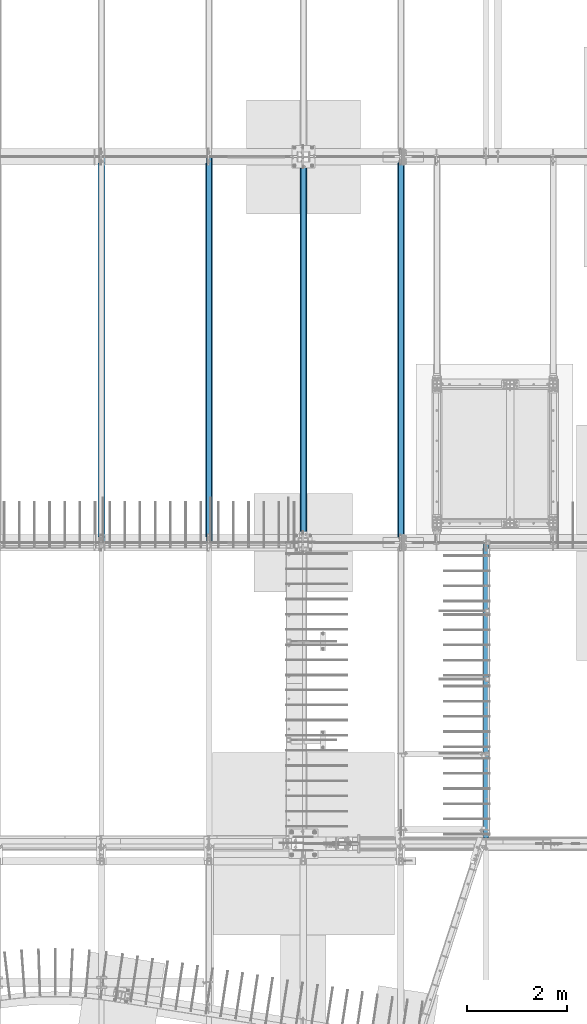
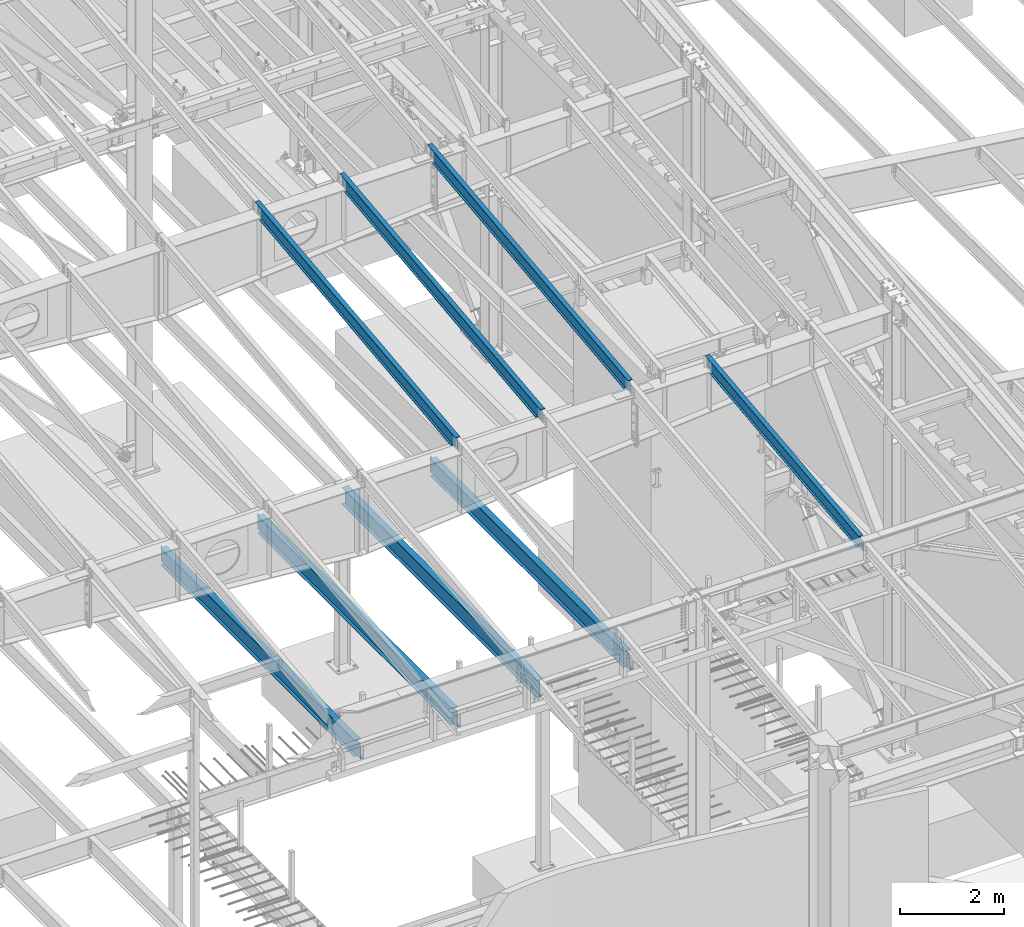
# One storey, part 719 of 1179: 8 beams, 8 elements without a shape of their own.
"""IFC2X3 building model written with IfcOpenShell, lengths in millimetres."""

from ifc_helpers import new_model, si_unit, frame, origin_with_axes, place, context, subcontext, project, spatial, faceted_brep, material, type_object, element, aggregate, save


model = new_model("IFC2X3")

# Units and contexts
model_context = context("Model", 3, precision=1e-05, world=origin_with_axes())
body_context = subcontext(model_context, "Body", "Model", "MODEL_VIEW")
ifc_project = project(units=[si_unit("LENGTHUNIT", "METRE", prefix="MILLI"), si_unit("AREAUNIT", "SQUARE_METRE"), si_unit("VOLUMEUNIT", "CUBIC_METRE"), si_unit("MASSUNIT", "GRAM", prefix="KILO"), si_unit("TIMEUNIT", "SECOND"), si_unit("PLANEANGLEUNIT", "RADIAN"), si_unit("SOLIDANGLEUNIT", "STERADIAN"), si_unit("THERMODYNAMICTEMPERATUREUNIT", "DEGREE_CELSIUS"), si_unit("LUMINOUSINTENSITYUNIT", "LUMEN")], contexts=[model_context])

# Site, building, storey
site_placement = place(None, origin_with_axes())
site = spatial("IfcSite", under=ifc_project, at=site_placement, CompositionType="ELEMENT")
building_placement = place(site_placement, origin_with_axes())
building = spatial("IfcBuilding", under=site, at=building_placement, Name="Undefined", CompositionType="ELEMENT")
storey_placement = place(building_placement, origin_with_axes())
storey = spatial("IfcBuildingStorey", under=building, at=storey_placement, Name="Undefined", CompositionType="ELEMENT", Elevation=0.0)

# Assembly, beam
assembly_1_placement = place(storey_placement, origin_with_axes())
assembly_1 = element("IfcElementAssembly", 1, at=assembly_1_placement, inside=storey, Name="BEAM", AssemblyPlace="NOTDEFINED", PredefinedType="RIGID_FRAME")
ifc_material = material(Name="STEEL/A992")
beam_type_1 = type_object("IfcBeamType", Name="W12X14", PredefinedType="NOTDEFINED")
beam_1_placement = place(assembly_1_placement, frame((20129.5, 5452.5431792468, 9711.23798851528), z_axis=(0.0, -0.112284087038017, 0.993676146336441), x_axis=(0.0, 0.993676146336441, 0.112284087038017)))
beam_1 = element("IfcBeam", 2, at=beam_1_placement, type_object=beam_type_1, material=ifc_material, Name="BEAM", ObjectType="W12X14", context=body_context, shape_type="Brep", body=[
    faceted_brep([(5871.37503272929, -2.38124999999854, -144.462500002917), (5871.37503272929, -50.7999999999993, -144.462500002917), (5870.65749114864, -50.7999999999993, -150.812500002912), (5870.65749114864, 50.7999999999993, -150.812500002912), (5871.37503272929, 50.7999999999993, -144.462500002917), (5871.37503272928, 2.38124783346939, -144.462500002968), (5874.19845246322, 2.38122628119891, -119.476191482236), (5874.19845246322, -2.38124999999854, -119.476191482236), (5875.70477851863, 2.38122688934163, -114.755394783042), (5875.70477851863, -2.38124999999854, -114.755394783042), (5878.90301301472, 2.38122737693629, -110.970393360541), (5878.90301301472, -2.38124999999854, -110.970393360541), (5883.30625374162, 2.38122766974266, -108.697419370077), (5883.30625374162, -2.38124999999854, -108.697419370077), (5888.24414721426, 2.38122772319184, -108.282512497075), (5888.24414721426, -2.38124999999854, -108.282512497075), (6045.98095926941, -2.38124999999854, -126.106563095373), (6045.98095929506, 2.38124999999854, -126.10656309827), (6076.55490468175, -50.7999999999993, 144.462499996846), (6077.27244626239, -50.7999999999993, 150.812499996842), (114.228614327105, -50.7999999999993, 150.812499999873), (113.511072746461, -50.7999999999993, 144.462499999876), (6077.27244626239, 50.7999999999993, 150.812499996842), (114.228614327105, 50.7999999999993, 150.812499999873), (6076.55490468175, 50.7999999999993, 144.462499996846), (113.511072746461, 50.7999999999993, 144.462499999876), (6076.55490468175, 2.38124999999854, 144.462499996846), (113.511072746461, 2.38124999999854, 144.462499999876), (136.689207968453, 50.7999999999993, -144.462500000005), (136.689207968449, 50.7999999999993, -150.8125), (136.689200027815, 2.38132415300061, -150.812500000002), (136.689200027785, 2.38117582134146, -144.462500001737), (-15.7107912112788, 2.38134914656257, -150.812499999922), (-14.9932496306401, 2.38124999999854, -144.462499999927), (136.689191329944, -50.7999999999993, -144.462500000003), (136.689199270568, -2.38124999999854, -144.462500000005), (136.689199270599, -2.38117588245223, -150.8125), (136.689191329941, -50.7999999999993, -150.8125), (-14.9932496306401, -2.38124999999854, -144.462499999927), (-15.7107912112788, -2.38115088886843, -150.812499999922), (-14.7278431263294, -2.38124999999854, -142.113742314172), (10.9745586429563, -2.38124999999854, 85.3438094690136), (10.9745586429563, 2.38124999999854, 85.3438094690136), (-14.7278305511045, 2.38124999999854, -142.113631027696), (93.0025247126168, -2.38124999999854, 76.0747580626012), (93.0025247126168, 2.38124999999854, 76.0747580626012), (97.9404181857699, -2.38124999999854, 76.4896649350048), (97.9404181857699, 2.38124999999854, 76.4896649350048), (102.343658913291, -2.38124999999854, 78.7626389252728), (102.343658913291, 2.38124999999854, 78.7626389252728), (105.541893409889, -2.38124999999854, 82.5476403479479), (105.541893409889, 2.38124999999854, 82.5476403479479), (107.048219465527, -2.38124999999854, 87.2684370475545), (107.048219465527, 2.38124999999854, 87.2684370475545), (113.511072746461, -2.38124999999854, 144.462499999876), (6076.55490468175, -2.38124999999854, 144.462499996846)], [[[0, 1, 2, 3, 4, 5, 6, 7]], [[7, 6, 8, 9]], [[9, 8, 10, 11]], [[11, 10, 12, 13]], [[13, 12, 14, 15]], [[16, 15, 14, 17]], [[18, 19, 20, 21]], [[19, 22, 23, 20]], [[22, 24, 25, 23]], [[24, 26, 27, 25]], [[28, 29, 30, 31]], [[31, 30, 32, 33]], [[34, 35, 36, 37]], [[38, 39, 36, 35]], [[40, 41, 42, 43, 33, 32, 39, 38]], [[44, 45, 42, 41]], [[46, 47, 45, 44]], [[48, 49, 47, 46]], [[50, 51, 49, 48]], [[52, 53, 51, 50]], [[20, 23, 25, 27, 53, 52, 54, 21]], [[55, 18, 21, 54]], [[26, 24, 22, 19, 18, 55, 16, 17]], [[12, 10, 8, 6, 5, 31, 33, 43, 42, 45, 47, 49, 51, 53, 27, 26, 17, 14]], [[28, 31, 5, 4]], [[29, 28, 4, 3]], [[37, 36, 39, 32, 30, 29, 3, 2]], [[34, 37, 2, 1]], [[35, 34, 1, 0]], [[55, 54, 52, 50, 48, 46, 44, 41, 40, 38, 35, 0, 7, 9, 11, 13, 15, 16]]]),
])
aggregate(assembly_1, [beam_1])

assembly_2_placement = place(storey_placement, origin_with_axes())
assembly_2 = element("IfcElementAssembly", 3, at=assembly_2_placement, inside=storey, Name="BEAM", AssemblyPlace="NOTDEFINED", PredefinedType="RIGID_FRAME")
beam_type_2 = type_object("IfcBeamType", Name="W16X31", PredefinedType="NOTDEFINED")
beam_2_placement = place(assembly_2_placement, frame((14566.9, 11480.8, 3900.4875), z_axis=(0.0, 0.0, 1.0), x_axis=(0.0, 1.0, 0.0)))
beam_2 = element("IfcBeam", 4, at=beam_2_placement, type_object=beam_type_2, material=ifc_material, Name="BEAM", ObjectType="W16X31", context=body_context, shape_type="Brep", body=[
    faceted_brep([(104.775000190735, -3.17499999999927, 169.8625), (104.775000190735, 3.17497090526012, 169.8625), (17.4625000000015, 3.17499999999927, 169.8625), (17.4625000000015, -3.17499999999927, 169.8625), (109.635079708782, -3.17499999999927, 170.829229922588), (109.635079708782, 3.17497028100843, 170.829229922588), (113.755256176935, -3.17499999999927, 173.582243823066), (113.755256176935, 3.17496850329189, 173.582243823066), (116.508270077413, -3.17499999999927, 177.702420291219), (116.508270077413, 3.17496584275432, 177.702420291219), (117.475, -3.17499999999927, 182.562499809265), (117.475, 3.17496270443371, 182.562499809265), (117.474999999999, -69.8499999999985, 201.6125), (117.474999999999, 69.8499999999985, 201.6125), (117.474999999999, 69.8499999999985, 190.5), (117.474999999999, 3.17499999999927, 190.5), (117.474999999999, -3.17499999999927, 190.5), (117.474999999999, -69.8499999999985, 190.5), (7601.74375, 3.17499999999927, -190.5), (7601.74375, 69.8499999999985, -190.5), (144.462499999994, 69.8499999999985, -190.5), (144.462499999994, 3.17549991607666, -190.5), (17.4624999999942, -3.17499999999927, -190.5), (17.4624999999942, -69.8499999999985, -190.5), (7728.74375, -69.8499999999985, -190.5), (7728.74375, -3.17499999999927, -190.5), (17.4624999999942, -69.8499999999985, -201.6125), (7728.74375, -69.8499999999985, -201.6125), (7601.74375, 69.8499999999985, -201.6125), (7601.74375, 3.17561705897606, -201.6125), (7728.74375, 3.17561705897606, -201.6125), (17.4624999999942, 3.17549991607666, -201.6125), (144.462499999994, 3.17549991607666, -201.6125), (144.462499999994, 69.8499999999985, -201.6125), (17.4624999999942, 3.17499999999927, -190.5), (7728.74375, 3.17499999999927, -190.5), (7728.74375, 3.17499999999927, 169.8625), (7728.74375, -3.17499999999927, 169.8625), (7633.49374980927, 3.17499999999927, 169.8625), (7633.49374980927, -3.17499999999927, 169.8625), (7628.63367029122, 3.17499999999927, 170.829229922588), (7628.63367029122, -3.17499999999927, 170.829229922588), (7624.51349382307, 3.17499999999927, 173.582243823066), (7624.51349382307, -3.17499999999927, 173.582243823066), (7621.76047992259, 3.17499999999927, 177.70242029122), (7621.76047992259, -3.17499999999927, 177.70242029122), (7620.79375, 3.17499999999927, 182.562499809265), (7620.79375, -3.17499999999927, 182.562499809265), (7620.79375, -69.8499999999985, 201.6125), (7620.79375, -69.8499999999985, 190.5), (7620.79375, -3.17499999999927, 190.5), (7620.79375, 3.17499999999927, 190.5), (7620.79375, 69.8499999999985, 190.5), (7620.79375, 69.8499999999985, 201.6125)], [[[0, 1, 2, 3]], [[4, 5, 1, 0]], [[6, 7, 5, 4]], [[8, 9, 7, 6]], [[10, 11, 9, 8]], [[12, 13, 14, 15, 11, 10, 16, 17]], [[18, 19, 20, 21]], [[22, 23, 24, 25]], [[23, 26, 27, 24]], [[28, 29, 30, 27, 26, 31, 32, 33]], [[21, 32, 31, 34]], [[20, 33, 32, 21]], [[19, 28, 33, 20]], [[18, 29, 28, 19]], [[35, 30, 29, 18]], [[25, 24, 27, 30, 35, 36, 37]], [[37, 36, 38, 39]], [[39, 38, 40, 41]], [[41, 40, 42, 43]], [[43, 42, 44, 45]], [[45, 44, 46, 47]], [[48, 49, 50, 47, 46, 51, 52, 53]], [[49, 48, 12, 17]], [[50, 49, 17, 16]], [[8, 6, 4, 0, 3, 22, 25, 37, 39, 41, 43, 45, 47, 50, 16, 10]], [[34, 31, 26, 23, 22, 3, 2]], [[51, 46, 44, 42, 40, 38, 36, 35, 18, 21, 34, 2, 1, 5, 7, 9, 11, 15]], [[52, 51, 15, 14]], [[53, 52, 14, 13]], [[48, 53, 13, 12]]]),
])
aggregate(assembly_2, [beam_2])

assembly_3_placement = place(storey_placement, origin_with_axes())
assembly_3 = element("IfcElementAssembly", 5, at=assembly_3_placement, inside=storey, Name="BEAM", AssemblyPlace="NOTDEFINED", PredefinedType="RIGID_FRAME")
beam_3_placement = place(assembly_3_placement, frame((12407.9, 11480.8, 3900.4875), z_axis=(0.0, 0.0, 1.0), x_axis=(0.0, 1.0, 0.0)))
beam_3 = element("IfcBeam", 6, at=beam_3_placement, type_object=beam_type_2, material=ifc_material, Name="BEAM", ObjectType="W16X31", context=body_context, shape_type="Brep", body=[
    faceted_brep([(7620.79375, -69.8499999999985, 201.6125), (7620.79375, -69.8499999999985, 190.5), (7620.79375, -3.17499999999927, 190.5), (7620.79375, -3.17499999999927, 182.562499809265), (7620.79375, 3.17499999999927, 182.562499809265), (7620.79375, 3.17499999999927, 190.5), (7620.79375, 69.8499999999985, 190.5), (7620.79375, 69.8499999999985, 201.6125), (7621.76047992259, -3.17499999999927, 177.70242029122), (7621.76047992259, 3.17499999999927, 177.70242029122), (7624.51349382307, -3.17499999999927, 173.582243823066), (7624.51349382307, 3.17499999999927, 173.582243823066), (7628.63367029122, -3.17499999999927, 170.829229922588), (7628.63367029122, 3.17499999999927, 170.829229922588), (7633.49374980927, -3.17499999999927, 169.8625), (7633.49374980927, 3.17499999999927, 169.8625), (7728.74375, -3.17499999999927, 169.8625), (7728.74375, 3.17499999999927, 169.8625), (117.474999999999, -69.8499999999985, 201.6125), (117.474999999999, 69.8499999999985, 201.6125), (117.474999999999, 69.8499999999985, 190.5), (117.474999999999, 3.17499999999927, 190.5), (117.475, 3.17496270443371, 182.562499809265), (117.475, -3.17499999999927, 182.562499809265), (117.474999999999, -3.17499999999927, 190.5), (117.474999999999, -69.8499999999985, 190.5), (116.508270077413, 3.17496584275432, 177.702420291219), (116.508270077413, -3.17499999999927, 177.702420291219), (113.755256176935, 3.17496850329189, 173.582243823066), (113.755256176935, -3.17499999999927, 173.582243823066), (109.635079708782, 3.17497028100843, 170.829229922588), (109.635079708782, -3.17499999999927, 170.829229922588), (104.775000190735, 3.17497090526012, 169.8625), (104.775000190735, -3.17499999999927, 169.8625), (17.4625000000015, 3.17499999999927, 169.8625), (17.4625000000015, -3.17499999999927, 169.8625), (17.4624999999942, 3.17499999999927, -190.5), (17.4624999999942, 3.17549991607666, -201.6125), (17.4624999999942, -69.8499999999985, -201.6125), (17.4624999999942, -69.8499999999985, -190.5), (17.4624999999942, -3.17499999999927, -190.5), (144.462499999994, 3.17549991607666, -190.5), (144.462499999994, 3.17549991607666, -201.6125), (144.462499999994, 69.8499999999985, -190.5), (144.462499999994, 69.8499999999985, -201.6125), (7601.74375, 3.17499999999927, -190.5), (7601.74375, 69.8499999999985, -190.5), (7601.74375, 69.8499999999985, -201.6125), (7601.74375, 3.17561705897606, -201.6125), (7728.74375, 3.17499999999927, -190.5), (7728.74375, 3.17561705897606, -201.6125), (7728.74375, -69.8499999999985, -201.6125), (7728.74375, -69.8499999999985, -190.5), (7728.74375, -3.17499999999927, -190.5)], [[[0, 1, 2, 3, 4, 5, 6, 7]], [[8, 9, 4, 3]], [[10, 11, 9, 8]], [[12, 13, 11, 10]], [[14, 15, 13, 12]], [[16, 17, 15, 14]], [[18, 19, 20, 21, 22, 23, 24, 25]], [[23, 22, 26, 27]], [[27, 26, 28, 29]], [[29, 28, 30, 31]], [[31, 30, 32, 33]], [[33, 32, 34, 35]], [[36, 37, 38, 39, 40, 35, 34]], [[41, 42, 37, 36]], [[43, 44, 42, 41]], [[45, 46, 43, 41]], [[46, 47, 44, 43]], [[45, 48, 47, 46]], [[49, 50, 48, 45]], [[47, 48, 50, 51, 38, 37, 42, 44]], [[39, 38, 51, 52]], [[40, 39, 52, 53]], [[27, 29, 31, 33, 35, 40, 53, 16, 14, 12, 10, 8, 3, 2, 24, 23]], [[2, 1, 25, 24]], [[1, 0, 18, 25]], [[0, 7, 19, 18]], [[7, 6, 20, 19]], [[6, 5, 21, 20]], [[5, 4, 9, 11, 13, 15, 17, 49, 45, 41, 36, 34, 32, 30, 28, 26, 22, 21]], [[53, 52, 51, 50, 49, 17, 16]]]),
])
aggregate(assembly_3, [beam_3])

assembly_4_placement = place(storey_placement, origin_with_axes())
assembly_4 = element("IfcElementAssembly", 7, at=assembly_4_placement, inside=storey, Name="BEAM", AssemblyPlace="NOTDEFINED", PredefinedType="RIGID_FRAME")
beam_4_placement = place(assembly_4_placement, frame((16459.2, 11480.8, 3900.4875), z_axis=(0.0, 0.0, 1.0), x_axis=(0.0, 1.0, 0.0)))
beam_4 = element("IfcBeam", 8, at=beam_4_placement, type_object=beam_type_2, material=ifc_material, Name="BEAM", ObjectType="W16X31", context=body_context, shape_type="Brep", body=[
    faceted_brep([(114.299999999999, -69.8500000000004, -190.5), (114.299999999999, -69.8500000000004, -201.6125), (7632.7, -69.8500000000004, -201.6125), (7632.7, -69.8500000000004, -190.5), (114.299999999999, -3.17499999999927, -190.5), (7632.7, -3.17499999999927, -190.5), (114.299999999999, -3.17499999999927, 190.5), (7632.7, -3.17499999999927, 190.5), (114.299999999999, -69.8500000000004, 190.5), (7632.7, -69.8500000000004, 190.5), (114.299999999999, -69.8500000000004, 201.6125), (7632.7, -69.8500000000004, 201.6125), (114.299999999999, 69.8500000000004, 201.6125), (7632.7, 69.8500000000004, 201.6125), (114.299999999999, 69.8500000000004, 190.5), (7632.7, 69.8500000000004, 190.5), (114.299999999999, 3.17499999999927, 190.5), (7632.7, 3.17499999999927, 190.5), (114.299999999999, 3.17499999999927, -190.5), (7632.7, 3.17499999999927, 164.252500725411), (7632.7, 3.17499999999927, -142.0275032968), (7632.7, 3.17499999999927, -190.5), (114.299999999999, 69.8500000000004, -190.5), (7632.7, 69.8500000000004, -190.5), (114.299999999999, 69.8500000000004, -201.6125), (7632.7, 69.8500000000004, -201.6125)], [[[0, 1, 2, 3]], [[4, 0, 3, 5]], [[6, 4, 5, 7]], [[8, 6, 7, 9]], [[10, 8, 9, 11]], [[12, 10, 11, 13]], [[14, 12, 13, 15]], [[16, 14, 15, 17]], [[18, 16, 17, 19, 20, 21]], [[22, 18, 21, 23]], [[1, 0, 4, 6, 8, 10, 12, 14, 16, 18, 22, 24]], [[1, 24, 25, 2]], [[21, 20, 19, 17, 15, 13, 11, 9, 7, 5, 3, 2, 25, 23]], [[24, 22, 23, 25]]]),
])
aggregate(assembly_4, [beam_4])

assembly_5_placement = place(storey_placement, origin_with_axes())
assembly_5 = element("IfcElementAssembly", 9, at=assembly_5_placement, inside=storey, Name="BEAM", AssemblyPlace="NOTDEFINED", PredefinedType="RIGID_FRAME")
beam_5_placement = place(assembly_5_placement, frame((18415.0, 11480.8, 3900.4875), z_axis=(0.0, 0.0, 1.0), x_axis=(0.0, 1.0, 0.0)))
beam_5 = element("IfcBeam", 10, at=beam_5_placement, type_object=beam_type_2, material=ifc_material, Name="BEAM", ObjectType="W16X31", context=body_context, shape_type="Brep", body=[
    faceted_brep([(104.775000190735, -3.17499999999927, 169.8625), (104.775000190735, 3.17497090526012, 169.8625), (17.4625000000015, 3.17499999999927, 169.8625), (17.4625000000015, -3.17499999999927, 169.8625), (109.635079708782, -3.17499999999927, 170.829229922588), (109.635079708782, 3.17497028100843, 170.829229922588), (113.755256176935, -3.17499999999927, 173.582243823066), (113.755256176935, 3.17496850329189, 173.582243823066), (116.508270077413, -3.17499999999927, 177.702420291219), (116.508270077413, 3.17496584275432, 177.702420291219), (117.475, -3.17499999999927, 182.562499809265), (117.475, 3.17496270443371, 182.562499809265), (117.474999999999, -69.8499999999985, 201.6125), (117.474999999999, 69.8499999999985, 201.6125), (117.474999999999, 69.8499999999985, 190.5), (117.474999999999, 3.17499999999927, 190.5), (117.474999999999, -3.17499999999927, 190.5), (117.474999999999, -69.8499999999985, 190.5), (7601.74375, 3.17499999999927, -190.5), (7601.74375, 69.8499999999985, -190.5), (144.462499999994, 69.8499999999985, -190.5), (144.462499999994, 3.17549991607666, -190.5), (17.4624999999942, -3.17499999999927, -190.5), (17.4624999999942, -69.8499999999985, -190.5), (7728.74375, -69.8499999999985, -190.5), (7728.74375, -3.17499999999927, -190.5), (17.4624999999942, -69.8499999999985, -201.6125), (7728.74375, -69.8499999999985, -201.6125), (7601.74375, 69.8499999999985, -201.6125), (7601.74375, 3.17561705897606, -201.6125), (7728.74375, 3.17561705897606, -201.6125), (17.4624999999942, 3.17549991607666, -201.6125), (144.462499999994, 3.17549991607666, -201.6125), (144.462499999994, 69.8499999999985, -201.6125), (17.4624999999942, 3.17499999999927, -190.5), (7728.74375, 3.17499999999927, -190.5), (7728.74375, 3.17499999999927, 169.8625), (7728.74375, -3.17499999999927, 169.8625), (7633.49374980927, 3.17499999999927, 169.8625), (7633.49374980927, -3.17499999999927, 169.8625), (7628.63367029122, 3.17499999999927, 170.829229922588), (7628.63367029122, -3.17499999999927, 170.829229922588), (7624.51349382307, 3.17499999999927, 173.582243823066), (7624.51349382307, -3.17499999999927, 173.582243823066), (7621.76047992259, 3.17499999999927, 177.70242029122), (7621.76047992259, -3.17499999999927, 177.70242029122), (7620.79375, 3.17499999999927, 182.562499809265), (7620.79375, -3.17499999999927, 182.562499809265), (7620.79375, -69.8499999999985, 201.6125), (7620.79375, -69.8499999999985, 190.5), (7620.79375, -3.17499999999927, 190.5), (7620.79375, 3.17499999999927, 190.5), (7620.79375, 69.8499999999985, 190.5), (7620.79375, 69.8499999999985, 201.6125)], [[[0, 1, 2, 3]], [[4, 5, 1, 0]], [[6, 7, 5, 4]], [[8, 9, 7, 6]], [[10, 11, 9, 8]], [[12, 13, 14, 15, 11, 10, 16, 17]], [[18, 19, 20, 21]], [[22, 23, 24, 25]], [[23, 26, 27, 24]], [[28, 29, 30, 27, 26, 31, 32, 33]], [[21, 32, 31, 34]], [[20, 33, 32, 21]], [[19, 28, 33, 20]], [[18, 29, 28, 19]], [[35, 30, 29, 18]], [[25, 24, 27, 30, 35, 36, 37]], [[37, 36, 38, 39]], [[39, 38, 40, 41]], [[41, 40, 42, 43]], [[43, 42, 44, 45]], [[45, 44, 46, 47]], [[48, 49, 50, 47, 46, 51, 52, 53]], [[49, 48, 12, 17]], [[50, 49, 17, 16]], [[8, 6, 4, 0, 3, 22, 25, 37, 39, 41, 43, 45, 47, 50, 16, 10]], [[34, 31, 26, 23, 22, 3, 2]], [[51, 46, 44, 42, 40, 38, 36, 35, 18, 21, 34, 2, 1, 5, 7, 9, 11, 15]], [[52, 51, 15, 14]], [[53, 52, 14, 13]], [[48, 53, 13, 12]]]),
])
aggregate(assembly_5, [beam_5])

assembly_6_placement = place(storey_placement, origin_with_axes())
assembly_6 = element("IfcElementAssembly", 11, at=assembly_6_placement, inside=storey, Name="BEAM", AssemblyPlace="NOTDEFINED", PredefinedType="RIGID_FRAME")
beam_type_3 = type_object("IfcBeamType", Name="W12X22", PredefinedType="NOTDEFINED")
beam_6_placement = place(assembly_6_placement, frame((18415.0, 11498.2779321842, 10389.6051906331), z_axis=(0.0, -0.112284087038017, 0.993676146336441), x_axis=(0.0, 0.993676146336441, 0.112284087038017)))
beam_6 = element("IfcBeam", 12, at=beam_6_placement, type_object=beam_type_3, material=ifc_material, Name="BEAM", ObjectType="W12X22", context=body_context, shape_type="Brep", body=[
    faceted_brep([(7577.0768884033, -3.17499999999927, -144.46250000299), (7577.0768884033, -50.7999999999993, -144.46250000299), (7575.82119063717, -50.7999999999993, -155.575000002984), (7575.82119063717, 50.7999999999993, -155.575000002984), (7577.0768884033, 50.7999999999993, -144.46250000299), (7577.0768884033, 3.17499999999927, -144.46250000299), (7581.95449107047, 3.17499999999927, -101.29736815286), (7581.95449107047, -3.17499999999927, -101.29736815286), (7583.46081712589, 3.17499999999927, -96.5765714536519), (7583.46081712589, -3.17499999999927, -96.5765714536519), (7586.659051622, 3.17499999999927, -92.7915700311405), (7586.659051622, -3.17499999999927, -92.7915700311405), (7591.06229234892, 3.17499999999927, -90.5185960406798), (7591.06229234892, -3.17499999999927, -90.5185960406798), (7596.00018582157, 3.17499999999927, -90.103689167694), (7596.00018582157, -3.17499999999927, -90.103689167694), (7760.04684140558, -3.17499999999927, -108.640743718448), (7760.04684144763, 3.17499999999927, -108.640743723199), (6.38101702707718, -50.7999999999993, 155.574999999912), (5.12531926095107, -50.7999999999993, 144.46249999992), (7788.64717240277, -50.7999999999993, 144.462499996762), (7789.9028701689, -50.7999999999993, 155.574999996754), (6.38101702707718, 50.7999999999993, 155.574999999912), (7789.9028701689, 50.7999999999993, 155.574999996754), (5.12531926095107, 50.7999999999993, 144.46249999992), (7788.64717240277, 50.7999999999993, 144.462499996762), (5.12531926095107, 3.17499999999927, 144.46249999992), (7788.64717240277, 3.17499999999927, 144.462499996762), (151.613288428754, -3.17499999999927, -142.735230056252), (151.613288428754, 3.17499999999927, -142.735230056252), (151.418108966391, 3.17499999999927, -144.46249999998), (151.418108966391, 50.7999999999993, -144.46249999998), (150.1624112014, 50.7999999999993, -155.574999999972), (150.1624112014, -50.7999999999993, -155.574999999972), (151.418108966391, -50.7999999999993, -144.46249999998), (151.418108966391, -3.17499999999927, -144.46249999998), (151.198381556816, -3.17499999999927, -137.797336586505), (151.198381556816, 3.17499999999927, -137.797336586505), (148.925407569488, -3.17499999999927, -133.394095861326), (148.925407569488, 3.17499999999927, -133.394095861326), (145.140406151304, -3.17499999999927, -130.195861364717), (145.140406151304, 3.17499999999927, -130.195861364717), (140.419609456261, -3.17499999999927, -128.689535306048), (140.419609456261, 3.17499999999927, -128.689535306048), (-23.6455988019097, -3.17499999999927, -110.150384137973), (-23.6455988019097, 3.17499999999927, -110.150384137973), (5.12531926095107, -3.17499999999927, 144.46249999992), (7788.64717240277, -3.17499999999927, 144.462499996762)], [[[0, 1, 2, 3, 4, 5, 6, 7]], [[7, 6, 8, 9]], [[9, 8, 10, 11]], [[11, 10, 12, 13]], [[13, 12, 14, 15]], [[16, 15, 14, 17]], [[18, 19, 20, 21]], [[22, 18, 21, 23]], [[24, 22, 23, 25]], [[26, 24, 25, 27]], [[28, 29, 30, 31, 32, 33, 34, 35]], [[36, 37, 29, 28]], [[38, 39, 37, 36]], [[40, 41, 39, 38]], [[42, 43, 41, 40]], [[44, 45, 43, 42]], [[46, 19, 18, 22, 24, 26, 45, 44]], [[19, 46, 47, 20]], [[27, 25, 23, 21, 20, 47, 16, 17]], [[12, 10, 8, 6, 5, 30, 29, 37, 39, 41, 43, 45, 26, 27, 17, 14]], [[31, 30, 5, 4]], [[32, 31, 4, 3]], [[33, 32, 3, 2]], [[34, 33, 2, 1]], [[35, 34, 1, 0]], [[47, 46, 44, 42, 40, 38, 36, 28, 35, 0, 7, 9, 11, 13, 15, 16]]]),
])
aggregate(assembly_6, [beam_6])

assembly_7_placement = place(storey_placement, origin_with_axes())
assembly_7 = element("IfcElementAssembly", 13, at=assembly_7_placement, inside=storey, Name="BEAM", AssemblyPlace="NOTDEFINED", PredefinedType="RIGID_FRAME")
beam_7_placement = place(assembly_7_placement, frame((16459.2, 11498.2779321842, 10389.6051906331), z_axis=(0.0, -0.112284087038017, 0.993676146336441), x_axis=(0.0, 0.993676146336441, 0.112284087038017)))
beam_7 = element("IfcBeam", 14, at=beam_7_placement, type_object=beam_type_3, material=ifc_material, Name="BEAM", ObjectType="W12X22", context=body_context, shape_type="Brep", body=[
    faceted_brep([(7583.46730043383, -3.17499999999927, -144.462500002994), (7583.46730043383, -50.7999999999993, -144.462500002994), (7582.21160266769, -50.7999999999993, -155.575000002988), (7582.21160266769, 50.7999999999993, -155.575000002988), (7583.46730043383, 50.7999999999993, -144.462500002994), (7583.46730043383, 3.17499999999927, -144.462500002994), (7586.83832669432, 3.17499999999927, -114.630059163946), (7586.83832669432, -3.17499999999927, -114.630059163946), (7588.34465274973, 3.17499999999927, -109.909262464753), (7588.34465274973, -3.17499999999927, -109.909262464753), (7591.54288724583, 3.17499999999927, -106.124261042249), (7591.54288724583, -3.17499999999927, -106.124261042249), (7595.94612797272, 3.17499999999927, -103.851287051781), (7595.94612797272, -3.17499999999927, -103.851287051781), (7600.88402144536, 3.17499999999927, -103.436380178771), (7600.88402144536, -3.17499999999927, -103.436380178771), (7758.6208335002, -3.17499999999927, -121.260430776909), (7758.62083354224, 3.17499999999927, -121.26043078166), (6.38101702707718, -50.7999999999993, 155.574999999912), (5.12531926095107, -50.7999999999993, 144.46249999992), (7788.64717240277, -50.7999999999993, 144.462499996762), (7789.9028701689, -50.7999999999993, 155.574999996754), (6.38101702707718, 50.7999999999993, 155.574999999912), (7789.9028701689, 50.7999999999993, 155.574999996754), (5.12531926095107, 50.7999999999993, 144.46249999992), (7788.64717240277, 50.7999999999993, 144.462499996762), (5.12531926095107, 3.17499999999927, 144.46249999992), (7788.64717240277, 3.17499999999927, 144.462499996762), (145.30344487597, -3.17499999999927, -142.022226300664), (145.30344487597, 3.17499999999927, -142.022226300664), (145.027696926005, 3.17499999999927, -144.462499999976), (145.027696926005, 50.7999999999993, -144.462499999976), (143.771999161854, 50.7999999999993, -155.574999999972), (143.771999161854, -50.7999999999993, -155.574999999972), (145.027696926005, -50.7999999999993, -144.462499999976), (145.027696926005, -3.17499999999927, -144.462499999976), (-25.0716067072917, -3.17499999999927, -122.770071196437), (-25.0716067072917, 3.17499999999927, -122.770071196437), (5.12531926095107, -3.17499999999927, 144.46249999992), (7788.64717240277, -3.17499999999927, 144.462499996762)], [[[0, 1, 2, 3, 4, 5, 6, 7]], [[7, 6, 8, 9]], [[9, 8, 10, 11]], [[11, 10, 12, 13]], [[13, 12, 14, 15]], [[16, 15, 14, 17]], [[18, 19, 20, 21]], [[22, 18, 21, 23]], [[24, 22, 23, 25]], [[26, 24, 25, 27]], [[28, 29, 30, 31, 32, 33, 34, 35]], [[36, 37, 29, 28]], [[38, 19, 18, 22, 24, 26, 37, 36]], [[19, 38, 39, 20]], [[27, 25, 23, 21, 20, 39, 16, 17]], [[12, 10, 8, 6, 5, 30, 29, 37, 26, 27, 17, 14]], [[31, 30, 5, 4]], [[32, 31, 4, 3]], [[33, 32, 3, 2]], [[34, 33, 2, 1]], [[35, 34, 1, 0]], [[39, 38, 36, 28, 35, 0, 7, 9, 11, 13, 15, 16]]]),
])
aggregate(assembly_7, [beam_7])

assembly_8_placement = place(storey_placement, origin_with_axes())
assembly_8 = element("IfcElementAssembly", 15, at=assembly_8_placement, inside=storey, Name="BEAM", AssemblyPlace="NOTDEFINED", PredefinedType="RIGID_FRAME")
beam_8_placement = place(assembly_8_placement, frame((14566.9, 11498.2779321842, 10389.6051906331), z_axis=(0.0, -0.112284087038017, 0.993676146336441), x_axis=(0.0, 0.993676146336441, 0.112284087038017)))
beam_8 = element("IfcBeam", 16, at=beam_8_placement, type_object=beam_type_3, material=ifc_material, Name="BEAM", ObjectType="W12X22", context=body_context, shape_type="Brep", body=[
    faceted_brep([(7583.46730043383, -3.17499999999927, -144.462500002994), (7583.46730043383, -50.7999999999993, -144.462500002994), (7582.21160266769, -50.7999999999993, -155.575000002988), (7582.21160266769, 50.7999999999993, -155.575000002988), (7583.46730043383, 50.7999999999993, -144.462500002994), (7583.46730043383, 3.17499999999927, -144.462500002994), (7586.83832669432, 3.17499999999927, -114.630059163946), (7586.83832669432, -3.17499999999927, -114.630059163946), (7588.34465274973, 3.17499999999927, -109.909262464753), (7588.34465274973, -3.17499999999927, -109.909262464753), (7591.54288724583, 3.17499999999927, -106.124261042249), (7591.54288724583, -3.17499999999927, -106.124261042249), (7595.94612797272, 3.17499999999927, -103.851287051781), (7595.94612797272, -3.17499999999927, -103.851287051781), (7600.88402144536, 3.17499999999927, -103.436380178771), (7600.88402144536, -3.17499999999927, -103.436380178771), (7758.6208335002, -3.17499999999927, -121.260430776909), (7758.62083354224, 3.17499999999927, -121.26043078166), (6.38101702707718, -50.7999999999993, 155.574999999912), (5.12531926095107, -50.7999999999993, 144.46249999992), (7788.64717240277, -50.7999999999993, 144.462499996762), (7789.9028701689, -50.7999999999993, 155.574999996754), (6.38101702707718, 50.7999999999993, 155.574999999912), (7789.9028701689, 50.7999999999993, 155.574999996754), (5.12531926095107, 50.7999999999993, 144.46249999992), (7788.64717240277, 50.7999999999993, 144.462499996762), (5.12531926095107, 3.17499999999927, 144.46249999992), (7788.64717240277, 3.17499999999927, 144.462499996762), (145.30344487597, -3.17499999999927, -142.022226300664), (145.30344487597, 3.17499999999927, -142.022226300664), (145.027696926005, 3.17499999999927, -144.462499999976), (145.027696926005, 50.7999999999993, -144.462499999976), (143.771999161854, 50.7999999999993, -155.574999999972), (143.771999161854, -50.7999999999993, -155.574999999972), (145.027696926005, -50.7999999999993, -144.462499999976), (145.027696926005, -3.17499999999927, -144.462499999976), (-25.0716067072917, -3.17499999999927, -122.770071196437), (-25.0716067072917, 3.17499999999927, -122.770071196437), (5.12531926095107, -3.17499999999927, 144.46249999992), (7788.64717240277, -3.17499999999927, 144.462499996762)], [[[0, 1, 2, 3, 4, 5, 6, 7]], [[7, 6, 8, 9]], [[9, 8, 10, 11]], [[11, 10, 12, 13]], [[13, 12, 14, 15]], [[16, 15, 14, 17]], [[18, 19, 20, 21]], [[22, 18, 21, 23]], [[24, 22, 23, 25]], [[26, 24, 25, 27]], [[28, 29, 30, 31, 32, 33, 34, 35]], [[36, 37, 29, 28]], [[38, 19, 18, 22, 24, 26, 37, 36]], [[19, 38, 39, 20]], [[27, 25, 23, 21, 20, 39, 16, 17]], [[12, 10, 8, 6, 5, 30, 29, 37, 26, 27, 17, 14]], [[31, 30, 5, 4]], [[32, 31, 4, 3]], [[33, 32, 3, 2]], [[34, 33, 2, 1]], [[35, 34, 1, 0]], [[39, 38, 36, 28, 35, 0, 7, 9, 11, 13, 15, 16]]]),
])
aggregate(assembly_8, [beam_8])

save(model, "model.ifc")
